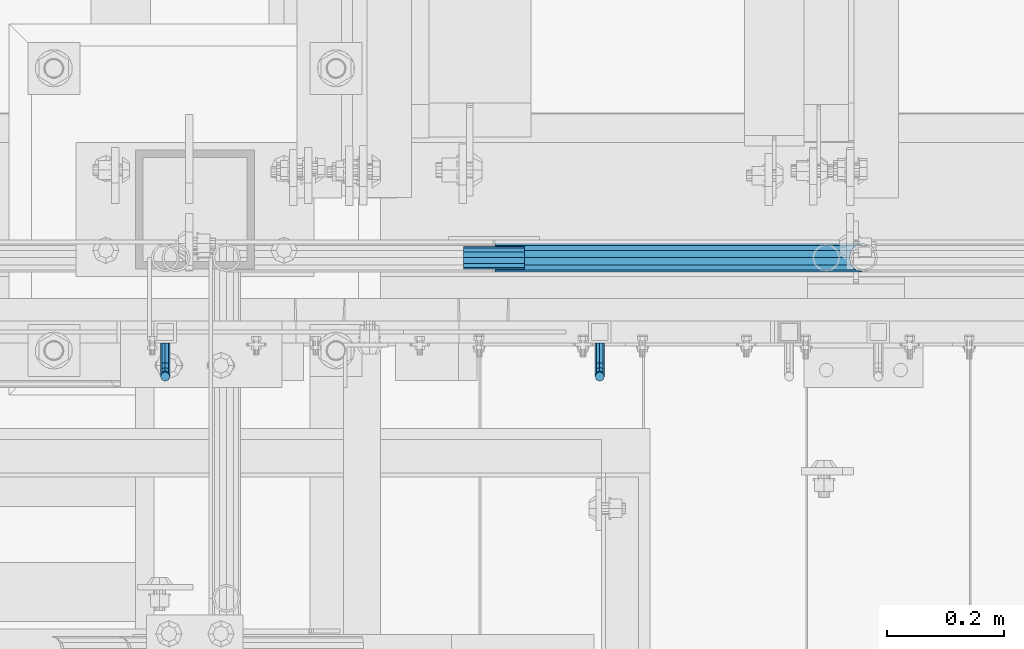
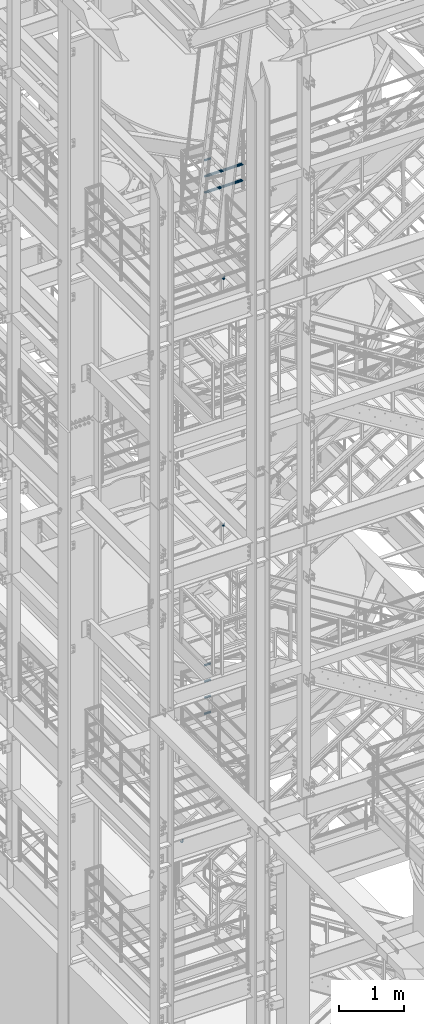
# One storey, part 1172 of 1876: 12 beams, 6 elements without a shape of their own.
"""IFC2X3 building model written with IfcOpenShell, lengths in millimetres."""

from ifc_helpers import new_model, si_unit, frame, origin_with_axes, place, context, subcontext, project, spatial, faceted_brep, material, type_object, element, aggregate, save


model = new_model("IFC2X3")

# Units and contexts
model_context = context("Model", 3, precision=1e-05, world=origin_with_axes())
body_context = subcontext(model_context, "Body", "Model", "MODEL_VIEW")
ifc_project = project(units=[si_unit("LENGTHUNIT", "METRE", prefix="MILLI"), si_unit("AREAUNIT", "SQUARE_METRE"), si_unit("VOLUMEUNIT", "CUBIC_METRE"), si_unit("MASSUNIT", "GRAM", prefix="KILO"), si_unit("TIMEUNIT", "SECOND"), si_unit("PLANEANGLEUNIT", "RADIAN"), si_unit("SOLIDANGLEUNIT", "STERADIAN"), si_unit("THERMODYNAMICTEMPERATUREUNIT", "DEGREE_CELSIUS"), si_unit("LUMINOUSINTENSITYUNIT", "LUMEN")], contexts=[model_context])

# Site, building, storey
site_placement = place(None, origin_with_axes())
site = spatial("IfcSite", under=ifc_project, at=site_placement, CompositionType="ELEMENT")
building_placement = place(site_placement, origin_with_axes())
building = spatial("IfcBuilding", under=site, at=building_placement, Name="Undefined", CompositionType="ELEMENT")
storey_placement = place(building_placement, origin_with_axes())
storey = spatial("IfcBuildingStorey", under=building, at=storey_placement, Name="Undefined", CompositionType="ELEMENT", Elevation=0.0)

# Assembly, beams
assembly_1_placement = place(storey_placement, origin_with_axes())
assembly_1 = element("IfcElementAssembly", 1, at=assembly_1_placement, inside=storey, Name="RAIL", AssemblyPlace="NOTDEFINED", PredefinedType="RIGID_FRAME")
ifc_material_1 = material()
beam_type_1 = type_object("IfcBeamType", Name="PIPE1-1/2SCH40", PredefinedType="NOTDEFINED")
beam_1_placement = place(assembly_1_placement, frame((2870.19999998823, -4654.55000114554, 18145.125), z_axis=(0.0, 0.0, 1.0), x_axis=(-1.0, 0.0, 0.0)))
beam_1 = element("IfcBeam", 2, at=beam_1_placement, type_object=beam_type_1, material=ifc_material_1, Name="RAIL", ObjectType="PIPE1-1/2SCH40", context=body_context, shape_type="Brep", body=[
    faceted_brep([(0.0, 24.1299999999992, 0.0), (12.0650000000064, 20.8971929933177, -12.0649999999987), (12.0650000000064, 20.8971929933177, 12.0649999999987), (12.0650000000064, -20.8971929933177, 12.0649999999987), (12.0650000000064, -20.8971929933177, -12.0649999999987), (0.0, -24.1299999999992, 0.0), (20.8971929933249, -12.0650000000005, 20.8971929933177), (20.8971929933249, -12.0650000000005, 15.8661214311796), (15.2545715621445, -17.7076214311801, 10.2235000000001), (12.5151929933249, -20.4470000000001, 0.0), (15.2545715621445, -17.7076214311801, -10.2235000000001), (20.8971929933249, -12.0650000000005, -15.8661214311796), (20.8971929933249, -12.0650000000005, -20.8971929933177), (24.1300000000063, 0.0, -20.4470000000001), (24.1300000000063, 0.0, -24.130000000001), (21.3906214311868, -10.2235000000001, -17.7076214311819), (21.3906214311868, 10.2235000000001, -17.7076214311819), (20.8971929933249, 12.0650000000005, -15.8661214311796), (20.8971929933249, 12.0650000000005, -20.8971929933177), (15.2545715621445, 17.7076214311801, -10.2235000000001), (12.5151929933249, 20.4470000000001, 0.0), (15.2545715621445, 17.7076214311801, 10.2235000000001), (20.8971929933249, 12.0650000000005, 15.8661214311796), (20.8971929933249, 12.0650000000005, 20.8971929933177), (21.3906214311868, 10.2235000000001, 17.7076214311819), (24.1300000000064, 0.0, 20.4470000000001), (24.1300000000064, 0.0, 24.130000000001), (21.3906214311868, -10.2235000000001, 17.7076214311819), (630.238000000001, -24.1300000000001, 0.0), (630.238000000001, -20.8971929933186, 12.0649999999987), (630.238000000001, -12.0649999999996, 20.8971929933177), (630.238000000001, 0.0, 24.130000000001), (630.238000000001, -12.0649999999996, -20.8971929933177), (630.238000000001, -20.8971929933186, -12.0649999999987), (630.238000000001, 0.0, -24.130000000001), (630.238000000001, 12.0649999999996, -20.8971929933177), (630.238000000001, 20.8971929933186, -12.0649999999987), (630.238000000001, 24.1300000000001, 0.0), (630.238000000001, 20.8971929933186, 12.0649999999987), (630.238000000001, 12.0649999999996, 20.8971929933177), (630.238000000001, -10.2235000000001, 17.7076214311819), (630.238000000001, 0.0, 20.4470000000001), (630.238000000001, 10.2235000000001, 17.7076214311819), (630.238000000001, 17.7076214311801, 10.2235000000001), (630.238000000001, 20.4470000000001, 0.0), (630.238000000001, 17.7076214311801, -10.2235000000001), (630.238000000001, 10.2235000000001, -17.7076214311819), (630.238000000001, 0.0, -20.4470000000001), (630.238000000001, -10.2235000000001, -17.7076214311819), (630.238000000001, -17.7076214311801, -10.2235000000001), (630.238000000001, -20.4470000000001, 0.0), (630.238000000001, -17.7076214311801, 10.2235000000001)], [[[0, 1, 2]], [[3, 4, 5]], [[6, 7, 8, 9, 10, 11, 12, 4, 3]], [[13, 14, 12, 11, 15]], [[16, 17, 18, 14, 13]], [[2, 1, 18, 17, 19, 20, 21, 22, 23]], [[23, 22, 24, 25, 26]], [[26, 25, 27, 7, 6]], [[28, 29, 3, 5]], [[29, 30, 6, 3]], [[30, 31, 26, 6]], [[32, 33, 4, 12]], [[34, 32, 12, 14]], [[35, 34, 14, 18]], [[36, 35, 18, 1]], [[37, 36, 1, 0]], [[38, 37, 0, 2]], [[39, 38, 2, 23]], [[31, 39, 23, 26]], [[33, 28, 5, 4]], [[32, 34, 35, 36, 37, 38, 39, 31, 30, 29, 28, 33], [40, 41, 42, 43, 44, 45, 46, 47, 48, 49, 50, 51]], [[42, 41, 25, 24]], [[21, 43, 42, 24, 22]], [[44, 43, 21, 20]], [[45, 44, 20, 19]], [[46, 45, 19, 17, 16]], [[47, 46, 16, 13]], [[48, 47, 13, 15]], [[10, 49, 48, 15, 11]], [[50, 49, 10, 9]], [[51, 50, 9, 8]], [[40, 51, 8, 7, 27]], [[41, 40, 27, 25]]]),
])
beam_2_placement = place(assembly_1_placement, frame((2238.37499998823, -4654.55000114554, 18449.925), z_axis=(0.0, 0.0, -1.0), x_axis=(1.0, 0.0, 0.0)))
beam_2 = element("IfcBeam", 3, at=beam_2_placement, type_object=beam_type_1, material=ifc_material_1, Name="RAIL", ObjectType="PIPE1-1/2SCH40", context=body_context, shape_type="Brep", body=[
    faceted_brep([(610.92780700668, -12.0649999999996, 20.8971929933177), (610.92780700668, -12.0650000000051, 15.866121431176), (610.434378568817, -10.2235000000001, 17.7076214311819), (607.694999999998, 0.0, 20.4470000000001), (607.694999999998, 0.0, 24.130000000001), (610.434378568819, 10.2235000000001, 17.7076214311819), (610.92780700668, 12.0649999999941, 15.8661214311869), (610.92780700668, 12.0649999999996, 20.8971929933177), (631.825, 24.1300000000001, 0.0), (619.759999999998, 20.8971929933186, 12.0649999999987), (619.759999999998, 20.8971929933186, -12.0649999999987), (616.570428437866, 17.7076214311801, 10.2235000000001), (619.309807006685, 20.4470000000001, 0.0), (616.570428437866, 17.7076214311801, -10.2235000000001), (610.92780700668, 12.0649999999941, -15.8661214311869), (610.92780700668, 12.0649999999996, -20.8971929933177), (610.434378568819, 10.2235000000001, -17.7076214311819), (607.694999999998, 0.0, -20.4470000000001), (607.694999999998, 0.0, -24.130000000001), (610.92780700668, -12.0650000000051, -15.866121431176), (610.92780700668, -12.0649999999996, -20.8971929933177), (610.434378568817, -10.2235000000001, -17.7076214311819), (631.824999999998, -24.1300000000056, 0.0), (619.759999999998, -20.8971929933186, -12.0649999999987), (619.759999999998, -20.8971929933186, 12.0649999999987), (616.570428437855, -17.7076214311801, -10.2235000000001), (619.309807006674, -20.4470000000001, 0.0), (616.570428437855, -17.7076214311801, 10.2235000000001), (1.58700000000044, -20.8971929933186, -12.0649999999996), (1.58700000000044, -12.0649999999996, -20.8971929933186), (1.58700000000044, 0.0, -24.1300000000001), (1.58700000000044, 12.0649999999996, -20.8971929933186), (1.58700000000044, 20.8971929933186, -12.0649999999996), (1.58700000000044, 24.1300000000001, 0.0), (1.58700000000044, 20.8971929933186, 12.0649999999996), (1.58700000000044, 12.0649999999996, 20.8971929933186), (1.58700000000044, 0.0, 24.1300000000001), (1.58700000000044, -12.0649999999996, 20.8971929933186), (1.58700000000044, -20.8971929933186, 12.0649999999996), (1.58700000000044, -24.1300000000001, 0.0), (1.58700000000044, -17.7076214311801, -10.2235000000001), (1.58700000000044, -10.2235000000001, -17.7076214311801), (1.58700000000044, 0.0, -20.4470000000001), (1.58700000000044, 10.2235000000001, -17.7076214311801), (1.58700000000044, 17.7076214311801, -10.2235000000001), (1.58700000000044, 20.4470000000001, 0.0), (1.58700000000044, 17.7076214311801, 10.2235000000001), (1.58700000000044, 10.2235000000001, 17.7076214311801), (1.58700000000044, 0.0, 20.4470000000001), (1.58700000000044, -10.2235000000001, 17.7076214311801), (1.58700000000044, -17.7076214311801, 10.2235000000001), (1.58700000000044, -20.4470000000001, 0.0)], [[[0, 1, 2, 3, 4]], [[4, 3, 5, 6, 7]], [[8, 9, 10]], [[7, 6, 11, 12, 13, 14, 15, 10, 9]], [[16, 17, 18, 15, 14]], [[19, 20, 18, 17, 21]], [[22, 23, 24]], [[24, 23, 20, 19, 25, 26, 27, 1, 0]], [[28, 29, 20, 23]], [[29, 30, 18, 20]], [[30, 31, 15, 18]], [[31, 32, 10, 15]], [[32, 33, 8, 10]], [[33, 34, 9, 8]], [[34, 35, 7, 9]], [[35, 36, 4, 7]], [[36, 37, 0, 4]], [[37, 38, 24, 0]], [[38, 39, 22, 24]], [[39, 28, 23, 22]], [[38, 37, 36, 35, 34, 33, 32, 31, 30, 29, 28, 39], [40, 41, 42, 43, 44, 45, 46, 47, 48, 49, 50, 51]], [[40, 51, 26, 25]], [[21, 41, 40, 25, 19]], [[42, 41, 21, 17]], [[43, 42, 17, 16]], [[44, 43, 16, 14, 13]], [[45, 44, 13, 12]], [[46, 45, 12, 11]], [[5, 47, 46, 11, 6]], [[48, 47, 5, 3]], [[49, 48, 3, 2]], [[50, 49, 2, 1, 27]], [[51, 50, 27, 26]]]),
])
aggregate(assembly_1, [beam_1, beam_2])

# Assembly, beam
assembly_2_placement = place(storey_placement, origin_with_axes())
assembly_2 = element("IfcElementAssembly", 4, at=assembly_2_placement, inside=storey, Name="RAIL", AssemblyPlace="NOTDEFINED", PredefinedType="RIGID_FRAME")
ifc_material_2 = material(Name="STEEL/A36")
beam_type_2 = type_object("IfcBeamType", PredefinedType="NOTDEFINED")
beam_3_placement = place(assembly_2_placement, frame((2419.35000034996, -4800.59999885446, 11882.9282225472), z_axis=(1.0, 0.0, 0.0), x_axis=(0.0, -1.0, 0.0)))
beam_3 = element("IfcBeam", 5, at=beam_3_placement, type_object=beam_type_2, material=ifc_material_2, Name="BRACKET", context=body_context, shape_type="Brep", body=[
    faceted_brep([(0.0, -5.61266007566822, 5.61266007566883), (0.0, 0.0, 7.9375), (0.0, 5.61266007566822, 5.61266007566883), (0.0, 7.9375, 0.0), (0.0, 5.61266007566822, -5.61266007566883), (0.0, 0.0, -7.9375), (0.0, -5.61266007566822, -5.61266007566883), (0.0, -7.9375, 0.0), (23.8125, 5.61266007566883, 5.61266007566792), (23.8125, 7.9375, 0.0), (23.8125, 5.61266007566883, -5.61266007566792), (23.8125, 0.0, -7.9375), (23.8125, -5.61266007566883, -5.61266007566792), (23.8125, -7.9375, 0.0), (23.8125, -5.61266007566883, 5.61266007566792), (23.8125, 0.0, 7.9375), (36.5702095103989, -2.53766620105534, 7.9375), (38.7180815328547, 2.64775556579752, 5.61266007566792), (39.6077592547972, 4.79562758825296, 0.0), (38.7180815328547, 2.64775556579752, -5.61266007566792), (36.5702095103989, -2.53766620105534, -7.9375), (34.4223374879439, -7.72308796790867, -5.61266007566792), (33.5326597660014, -9.87095999036364, 0.0), (34.4223374879439, -7.72308796790867, 5.61266007566792), (43.4169233967659, -13.733078129113, 5.61266007566792), (47.385673396765, -9.76432812911298, 7.9375), (41.7730133210971, -15.3769882047809, 0.0), (43.4169233967659, -13.733078129113, -5.61266007566792), (47.385673396765, -9.76432812911298, -7.9375), (51.354423396765, -5.79557812911253, -5.61266007566792), (52.9983334724338, -4.15166805344461, 0.0), (51.354423396765, -5.79557812911253, 5.61266007566792), (54.6123353248231, -20.5797920154787, 7.9375), (59.7977570916764, -18.4319199930233, 5.61266007566792), (49.4269135579698, -22.7276640379341, 5.61266007566792), (47.2790415355148, -23.6173417598766, 0.0), (49.4269135579698, -22.7276640379341, -5.61266007566792), (54.6123353248231, -20.5797920154787, -7.9375), (59.7977570916764, -18.4319199930233, -5.61266007566792), (61.9456291141314, -17.5422422710808, 0.0), (62.7626616015468, -33.3375015258789, 5.61266007566792), (65.0875015258789, -33.3375015258789, 0.0), (57.1500015258789, -33.3375015258789, 7.9375), (51.5373414502101, -33.3375015258789, 5.61266007566792), (49.2125015258789, -33.3375015258789, 0.0), (51.5373414502101, -33.3375015258789, -5.61266007566792), (57.1500015258789, -33.3375015258789, -7.9375), (62.7626616015468, -33.3375015258789, -5.61266007566792), (65.0875015258789, -66.5341532333514, 2.45290721068159e-09), (62.7626616015805, -63.0815171359536, -5.61266007334871), (57.1500015259289, -61.6513884384531, -7.93749999776537), (51.5373414502437, -63.0815171359118, -5.6126600734151), (49.2125015258789, -66.5341532333259, 2.41197994910181e-09), (51.5373414501864, -69.9867893307037, 5.61266007818085), (57.1500015258471, -71.4169180281988, 7.93750000258842), (62.7626616015223, -69.9867893307346, 5.61266007822906)], [[[0, 1, 2, 3, 4, 5, 6, 7]], [[3, 2, 8, 9]], [[4, 3, 9, 10]], [[5, 4, 10, 11]], [[6, 5, 11, 12]], [[7, 6, 12, 13]], [[0, 7, 13, 14]], [[1, 0, 14, 15]], [[2, 1, 15, 8]], [[8, 15, 16, 17]], [[9, 8, 17, 18]], [[10, 9, 18, 19]], [[11, 10, 19, 20]], [[12, 11, 20, 21]], [[13, 12, 21, 22]], [[14, 13, 22, 23]], [[15, 14, 23, 16]], [[23, 24, 25, 16]], [[22, 26, 24, 23]], [[21, 27, 26, 22]], [[20, 28, 27, 21]], [[19, 29, 28, 20]], [[18, 30, 29, 19]], [[17, 31, 30, 18]], [[16, 25, 31, 17]], [[25, 32, 33, 31]], [[24, 34, 32, 25]], [[26, 35, 34, 24]], [[27, 36, 35, 26]], [[28, 37, 36, 27]], [[29, 38, 37, 28]], [[30, 39, 38, 29]], [[31, 33, 39, 30]], [[33, 40, 41, 39]], [[32, 42, 40, 33]], [[34, 43, 42, 32]], [[35, 44, 43, 34]], [[36, 45, 44, 35]], [[37, 46, 45, 36]], [[38, 47, 46, 37]], [[39, 41, 47, 38]], [[47, 41, 48, 49]], [[46, 47, 49, 50]], [[45, 46, 50, 51]], [[44, 45, 51, 52]], [[43, 44, 52, 53]], [[42, 43, 53, 54]], [[40, 42, 54, 55]], [[41, 40, 55, 48]], [[54, 53, 52, 51, 50, 49, 48, 55]]]),
])
aggregate(assembly_2, [beam_3])

assembly_3_placement = place(storey_placement, origin_with_axes())
assembly_3 = element("IfcElementAssembly", 6, at=assembly_3_placement, inside=storey, Name="RAIL", AssemblyPlace="NOTDEFINED", PredefinedType="RIGID_FRAME")
beam_4_placement = place(assembly_3_placement, frame((1676.40000030575, -4800.59999885446, 6175.95228073486), z_axis=(1.0, 0.0, 0.0), x_axis=(0.0, -1.0, 0.0)))
beam_4 = element("IfcBeam", 7, at=beam_4_placement, type_object=beam_type_2, material=ifc_material_2, Name="BRACKET", context=body_context, shape_type="Brep", body=[
    faceted_brep([(0.0, -5.61266007566822, 5.61266007566883), (0.0, 0.0, 7.9375), (0.0, 5.61266007566822, 5.61266007566883), (0.0, 7.9375, 0.0), (0.0, 5.61266007566822, -5.61266007566883), (0.0, 0.0, -7.9375), (0.0, -5.61266007566822, -5.61266007566883), (0.0, -7.9375, 0.0), (23.8125, 5.61266007566883, 5.61266007566792), (23.8125, 7.9375, 0.0), (23.8125, 5.61266007566883, -5.61266007566792), (23.8125, 0.0, -7.9375), (23.8125, -5.61266007566883, -5.61266007566792), (23.8125, -7.9375, 0.0), (23.8125, -5.61266007566883, 5.61266007566792), (23.8125, 0.0, 7.9375), (36.5702095103989, -2.53766620105534, 7.9375), (38.7180815328547, 2.64775556579752, 5.61266007566792), (39.6077592547972, 4.79562758825296, 0.0), (38.7180815328547, 2.64775556579752, -5.61266007566792), (36.5702095103989, -2.53766620105534, -7.9375), (34.4223374879439, -7.72308796790867, -5.61266007566792), (33.5326597660014, -9.87095999036364, 0.0), (34.4223374879439, -7.72308796790867, 5.61266007566792), (43.4169233967659, -13.733078129113, 5.61266007566792), (47.385673396765, -9.76432812911298, 7.9375), (41.7730133210971, -15.3769882047809, 0.0), (43.4169233967659, -13.733078129113, -5.61266007566792), (47.385673396765, -9.76432812911298, -7.9375), (51.354423396765, -5.79557812911253, -5.61266007566792), (52.9983334724338, -4.15166805344461, 0.0), (51.354423396765, -5.79557812911253, 5.61266007566792), (54.6123353248231, -20.5797920154787, 7.9375), (59.7977570916764, -18.4319199930233, 5.61266007566792), (49.4269135579698, -22.7276640379341, 5.61266007566792), (47.2790415355148, -23.6173417598766, 0.0), (49.4269135579698, -22.7276640379341, -5.61266007566792), (54.6123353248231, -20.5797920154787, -7.9375), (59.7977570916764, -18.4319199930233, -5.61266007566792), (61.9456291141314, -17.5422422710808, 0.0), (62.7626616015468, -33.3375015258789, 5.61266007566792), (65.0875015258789, -33.3375015258789, 0.0), (57.1500015258789, -33.3375015258789, 7.9375), (51.5373414502101, -33.3375015258789, 5.61266007566792), (49.2125015258789, -33.3375015258789, 0.0), (51.5373414502101, -33.3375015258789, -5.61266007566792), (57.1500015258789, -33.3375015258789, -7.9375), (62.7626616015468, -33.3375015258789, -5.61266007566792), (65.0875015258789, -66.3198535804604, 0.0), (62.7626616015468, -62.7481608643047, -5.61266007566792), (57.1500015258789, -61.2687173006434, -7.9375), (51.537341450211, -62.7481608643047, -5.61266007566792), (49.2125015258789, -66.3198535804604, 0.0), (51.537341450211, -69.8915462966161, 5.61266007566792), (57.1500015258789, -71.3709898602756, 7.9375), (62.7626616015468, -69.8915462966161, 5.61266007566792)], [[[0, 1, 2, 3, 4, 5, 6, 7]], [[3, 2, 8, 9]], [[4, 3, 9, 10]], [[5, 4, 10, 11]], [[6, 5, 11, 12]], [[7, 6, 12, 13]], [[0, 7, 13, 14]], [[1, 0, 14, 15]], [[2, 1, 15, 8]], [[8, 15, 16, 17]], [[9, 8, 17, 18]], [[10, 9, 18, 19]], [[11, 10, 19, 20]], [[12, 11, 20, 21]], [[13, 12, 21, 22]], [[14, 13, 22, 23]], [[15, 14, 23, 16]], [[23, 24, 25, 16]], [[22, 26, 24, 23]], [[21, 27, 26, 22]], [[20, 28, 27, 21]], [[19, 29, 28, 20]], [[18, 30, 29, 19]], [[17, 31, 30, 18]], [[16, 25, 31, 17]], [[25, 32, 33, 31]], [[24, 34, 32, 25]], [[26, 35, 34, 24]], [[27, 36, 35, 26]], [[28, 37, 36, 27]], [[29, 38, 37, 28]], [[30, 39, 38, 29]], [[31, 33, 39, 30]], [[33, 40, 41, 39]], [[32, 42, 40, 33]], [[34, 43, 42, 32]], [[35, 44, 43, 34]], [[36, 45, 44, 35]], [[37, 46, 45, 36]], [[38, 47, 46, 37]], [[39, 41, 47, 38]], [[47, 41, 48, 49]], [[46, 47, 49, 50]], [[45, 46, 50, 51]], [[44, 45, 51, 52]], [[43, 44, 52, 53]], [[42, 43, 53, 54]], [[40, 42, 54, 55]], [[41, 40, 55, 48]], [[54, 53, 52, 51, 50, 49, 48, 55]]]),
])
aggregate(assembly_3, [beam_4])

assembly_4_placement = place(storey_placement, origin_with_axes())
assembly_4 = element("IfcElementAssembly", 8, at=assembly_4_placement, inside=storey, Name="RAIL", AssemblyPlace="NOTDEFINED", PredefinedType="RIGID_FRAME")
beam_5_placement = place(assembly_4_placement, frame((2419.34999989024, -4800.60000114554, 16540.4354524847), z_axis=(-1.0, 0.0, 0.0), x_axis=(0.0, -1.0, 0.0)))
beam_5 = element("IfcBeam", 9, at=beam_5_placement, type_object=beam_type_2, material=ifc_material_2, Name="BRACKET", context=body_context, shape_type="Brep", body=[
    faceted_brep([(0.0, -5.61266007566822, 5.61266007566883), (0.0, 0.0, 7.9375), (0.0, 5.61266007566822, 5.61266007566883), (0.0, 7.9375, 0.0), (0.0, 5.61266007566822, -5.61266007566883), (0.0, 0.0, -7.9375), (0.0, -5.61266007566822, -5.61266007566883), (0.0, -7.9375, 0.0), (23.8125, -5.61266007566883, -5.61266007566792), (23.8125, -7.9375, 0.0), (23.8125, -5.61266007566883, 5.61266007566792), (23.8125, 0.0, 7.9375), (23.8125, 5.61266007566883, 5.61266007566792), (23.8125, 7.9375, 0.0), (23.8125, 5.61266007566883, -5.61266007566792), (23.8125, 0.0, -7.9375), (36.5702095103998, 2.53766620105671, -7.9375), (38.7180815328556, -2.64775556579843, -5.61266007566792), (39.6077592547981, -4.79562758825341, 0.0), (38.7180815328556, -2.64775556579843, 5.61266007566792), (36.5702095103998, 2.53766620105671, 7.9375), (34.4223374879448, 7.72308796790821, 5.61266007566792), (33.5326597660023, 9.87095999036319, 0.0), (34.4223374879448, 7.72308796790821, -5.61266007566792), (43.4169233967659, 13.733078129113, -5.61266007566792), (47.3856733967659, 9.76432812911298, -7.9375), (41.773013321098, 15.3769882047818, 0.0), (43.4169233967659, 13.733078129113, 5.61266007566792), (47.3856733967659, 9.76432812911298, 7.9375), (51.3544233967659, 5.79557812911298, 5.61266007566792), (52.9983334724348, 4.15166805344415, 0.0), (51.3544233967659, 5.79557812911298, -5.61266007566792), (54.6123353248231, 20.5797920154801, -7.9375), (59.7977570916764, 18.4319199930251, -5.61266007566792), (49.4269135579698, 22.727664037935, -5.61266007566792), (47.2790415355148, 23.6173417598766, 0.0), (49.4269135579698, 22.727664037935, 5.61266007566792), (54.6123353248231, 20.5797920154801, 7.9375), (59.7977570916764, 18.4319199930251, 5.61266007566792), (61.9456291141314, 17.5422422710835, 0.0), (62.7626616015468, 33.3375015258789, -5.61266007566792), (65.0875015258789, 33.3375015258789, 0.0), (57.1500015258789, 33.3375015258789, -7.9375), (51.5373414502101, 33.3375015258789, -5.61266007566792), (49.2125015258789, 33.3375015258789, 0.0), (51.5373414502101, 33.3375015258789, 5.61266007566792), (57.1500015258789, 33.3375015258789, 7.9375), (62.7626616015468, 33.3375015258789, 5.61266007566792), (65.0875015258789, 66.4903820289292, 0.0), (62.7626616015468, 63.0131702244908, 5.61266007566837), (57.1500015258789, 61.5728619358488, 7.9375), (51.537341450211, 63.0131702244908, 5.61266007566837), (49.2125015258789, 66.4903820289292, 0.0), (51.537341450211, 69.9675938333676, -5.61266007566837), (57.1500015258789, 71.4079021220132, -7.9375), (62.7626616015468, 69.9675938333676, -5.61266007566837)], [[[0, 1, 2, 3, 4, 5, 6, 7]], [[7, 6, 8, 9]], [[0, 7, 9, 10]], [[1, 0, 10, 11]], [[2, 1, 11, 12]], [[3, 2, 12, 13]], [[4, 3, 13, 14]], [[5, 4, 14, 15]], [[6, 5, 15, 8]], [[8, 15, 16, 17]], [[9, 8, 17, 18]], [[10, 9, 18, 19]], [[11, 10, 19, 20]], [[12, 11, 20, 21]], [[13, 12, 21, 22]], [[14, 13, 22, 23]], [[15, 14, 23, 16]], [[23, 24, 25, 16]], [[22, 26, 24, 23]], [[21, 27, 26, 22]], [[20, 28, 27, 21]], [[19, 29, 28, 20]], [[18, 30, 29, 19]], [[17, 31, 30, 18]], [[16, 25, 31, 17]], [[25, 32, 33, 31]], [[24, 34, 32, 25]], [[26, 35, 34, 24]], [[27, 36, 35, 26]], [[28, 37, 36, 27]], [[29, 38, 37, 28]], [[30, 39, 38, 29]], [[31, 33, 39, 30]], [[33, 40, 41, 39]], [[32, 42, 40, 33]], [[34, 43, 42, 32]], [[35, 44, 43, 34]], [[36, 45, 44, 35]], [[37, 46, 45, 36]], [[38, 47, 46, 37]], [[39, 41, 47, 38]], [[47, 41, 48, 49]], [[46, 47, 49, 50]], [[45, 46, 50, 51]], [[44, 45, 51, 52]], [[43, 44, 52, 53]], [[42, 43, 53, 54]], [[40, 42, 54, 55]], [[41, 40, 55, 48]], [[54, 53, 52, 51, 50, 49, 48, 55]]]),
])
aggregate(assembly_4, [beam_5])

# Assembly, beams
assembly_5_placement = place(storey_placement, origin_with_axes())
assembly_5 = element("IfcElementAssembly", 10, at=assembly_5_placement, inside=storey, Name="RAIL", AssemblyPlace="NOTDEFINED", PredefinedType="RIGID_FRAME")
beam_type_3 = type_object("IfcBeamType", PredefinedType="NOTDEFINED")
beam_6_placement = place(assembly_5_placement, frame((2185.98799998823, -4654.54995231742, 18145.125), z_axis=(0.0, 0.0, 1.0), x_axis=(1.0, 0.0, 0.0)))
beam_6 = element("IfcBeam", 11, at=beam_6_placement, type_object=beam_type_3, material=ifc_material_2, Name="ROD", context=body_context, shape_type="Brep", body=[
    faceted_brep([(0.0, -18.8594999999996, 0.0), (0.0, -16.3328061026723, -9.42975000000024), (104.774, -16.3328061026723, -9.42975000000024), (104.774, -18.8594999999996, 0.0), (0.0, -9.42975000000024, -16.3328061026723), (104.774, -9.42975000000024, -16.3328061026723), (0.0, 0.0, -18.8594999999996), (104.774, 0.0, -18.8594999999996), (0.0, 9.42975000000024, -16.3328061026723), (104.774, 9.42975000000024, -16.3328061026723), (0.0, 16.3328061026723, -9.42975000000024), (104.774, 16.3328061026723, -9.42975000000024), (0.0, 18.8594999999996, 0.0), (104.774, 18.8594999999996, 0.0), (0.0, 16.3328061026723, 9.42975000000024), (104.774, 16.3328061026723, 9.42975000000024), (0.0, 9.42975000000024, 16.3328061026723), (104.774, 9.42975000000024, 16.3328061026723), (0.0, 0.0, 18.8594999999996), (104.774, 0.0, 18.8594999999996), (0.0, -9.42975000000024, 16.3328061026723), (104.774, -9.42975000000024, 16.3328061026723), (0.0, -16.3328061026723, 9.42975000000024), (104.774, -16.3328061026723, 9.42975000000024)], [[[0, 1, 2, 3]], [[1, 4, 5, 2]], [[4, 6, 7, 5]], [[6, 8, 9, 7]], [[8, 10, 11, 9]], [[10, 12, 13, 11]], [[12, 14, 15, 13]], [[14, 16, 17, 15]], [[16, 18, 19, 17]], [[18, 20, 21, 19]], [[20, 22, 23, 21]], [[22, 0, 3, 23]], [[5, 7, 9, 11, 13, 15, 17, 19, 21, 23, 3, 2]], [[22, 20, 18, 16, 14, 12, 10, 8, 6, 4, 1, 0]]]),
])
beam_7_placement = place(assembly_5_placement, frame((2185.98799998823, -4654.54995231742, 18449.925), z_axis=(0.0, 0.0, 1.0), x_axis=(1.0, 0.0, 0.0)))
beam_7 = element("IfcBeam", 12, at=beam_7_placement, type_object=beam_type_3, material=ifc_material_2, Name="ROD", context=body_context, shape_type="Brep", body=[
    faceted_brep([(0.0, -18.8594999999996, 0.0), (0.0, -16.3328061026723, -9.42975000000024), (104.774, -16.3328061026723, -9.42975000000024), (104.774, -18.8594999999996, 0.0), (0.0, -9.42975000000024, -16.3328061026723), (104.774, -9.42975000000024, -16.3328061026723), (0.0, 0.0, -18.8594999999996), (104.774, 0.0, -18.8594999999996), (0.0, 9.42975000000024, -16.3328061026723), (104.774, 9.42975000000024, -16.3328061026723), (0.0, 16.3328061026723, -9.42975000000024), (104.774, 16.3328061026723, -9.42975000000024), (0.0, 18.8594999999996, 0.0), (104.774, 18.8594999999996, 0.0), (0.0, 16.3328061026723, 9.42975000000024), (104.774, 16.3328061026723, 9.42975000000024), (0.0, 9.42975000000024, 16.3328061026723), (104.774, 9.42975000000024, 16.3328061026723), (0.0, 0.0, 18.8594999999996), (104.774, 0.0, 18.8594999999996), (0.0, -9.42975000000024, 16.3328061026723), (104.774, -9.42975000000024, 16.3328061026723), (0.0, -16.3328061026723, 9.42975000000024), (104.774, -16.3328061026723, 9.42975000000024)], [[[0, 1, 2, 3]], [[1, 4, 5, 2]], [[4, 6, 7, 5]], [[6, 8, 9, 7]], [[8, 10, 11, 9]], [[10, 12, 13, 11]], [[12, 14, 15, 13]], [[14, 16, 17, 15]], [[16, 18, 19, 17]], [[18, 20, 21, 19]], [[20, 22, 23, 21]], [[22, 0, 3, 23]], [[5, 7, 9, 11, 13, 15, 17, 19, 21, 23, 3, 2]], [[22, 20, 18, 16, 14, 12, 10, 8, 6, 4, 1, 0]]]),
])
beam_8_placement = place(assembly_5_placement, frame((2185.98799998823, -4654.54995231742, 18754.725), z_axis=(0.0, 0.0, 1.0), x_axis=(1.0, 0.0, 0.0)))
beam_8 = element("IfcBeam", 13, at=beam_8_placement, type_object=beam_type_3, material=ifc_material_2, Name="ROD", context=body_context, shape_type="Brep", body=[
    faceted_brep([(0.0, -18.8594999999996, 0.0), (0.0, -16.3328061026723, -9.42975000000024), (104.774, -16.3328061026723, -9.42975000000024), (104.774, -18.8594999999996, 0.0), (0.0, -9.42975000000024, -16.3328061026723), (104.774, -9.42975000000024, -16.3328061026723), (0.0, 0.0, -18.8594999999996), (104.774, 0.0, -18.8594999999996), (0.0, 9.42975000000024, -16.3328061026723), (104.774, 9.42975000000024, -16.3328061026723), (0.0, 16.3328061026723, -9.42975000000024), (104.774, 16.3328061026723, -9.42975000000024), (0.0, 18.8594999999996, 0.0), (104.774, 18.8594999999996, 0.0), (0.0, 16.3328061026723, 9.42975000000024), (104.774, 16.3328061026723, 9.42975000000024), (0.0, 9.42975000000024, 16.3328061026723), (104.774, 9.42975000000024, 16.3328061026723), (0.0, 0.0, 18.8594999999996), (104.774, 0.0, 18.8594999999996), (0.0, -9.42975000000024, 16.3328061026723), (104.774, -9.42975000000024, 16.3328061026723), (0.0, -16.3328061026723, 9.42975000000024), (104.774, -16.3328061026723, 9.42975000000024)], [[[0, 1, 2, 3]], [[1, 4, 5, 2]], [[4, 6, 7, 5]], [[6, 8, 9, 7]], [[8, 10, 11, 9]], [[10, 12, 13, 11]], [[12, 14, 15, 13]], [[14, 16, 17, 15]], [[16, 18, 19, 17]], [[18, 20, 21, 19]], [[20, 22, 23, 21]], [[22, 0, 3, 23]], [[5, 7, 9, 11, 13, 15, 17, 19, 21, 23, 3, 2]], [[22, 20, 18, 16, 14, 12, 10, 8, 6, 4, 1, 0]]]),
])
aggregate(assembly_5, [beam_6, beam_7, beam_8])

assembly_6_placement = place(storey_placement, origin_with_axes())
assembly_6 = element("IfcElementAssembly", 14, at=assembly_6_placement, inside=storey, Name="RAIL", AssemblyPlace="NOTDEFINED", PredefinedType="RIGID_FRAME")
beam_9_placement = place(assembly_6_placement, frame((2185.98799998823, -4654.54995231742, 8315.325), z_axis=(0.0, 0.0, 1.0), x_axis=(1.0, 0.0, 0.0)))
beam_9 = element("IfcBeam", 15, at=beam_9_placement, type_object=beam_type_3, material=ifc_material_2, Name="ROD", context=body_context, shape_type="Brep", body=[
    faceted_brep([(0.0, -18.8594999999996, 0.0), (0.0, -16.3328061026723, -9.42975000000024), (104.774, -16.3328061026723, -9.42975000000024), (104.774, -18.8594999999996, 0.0), (0.0, -9.42975000000024, -16.3328061026723), (104.774, -9.42975000000024, -16.3328061026723), (0.0, 0.0, -18.8594999999996), (104.774, 0.0, -18.8594999999996), (0.0, 9.42975000000024, -16.3328061026723), (104.774, 9.42975000000024, -16.3328061026723), (0.0, 16.3328061026723, -9.42975000000024), (104.774, 16.3328061026723, -9.42975000000024), (0.0, 18.8594999999996, 0.0), (104.774, 18.8594999999996, 0.0), (0.0, 16.3328061026723, 9.42975000000024), (104.774, 16.3328061026723, 9.42975000000024), (0.0, 9.42975000000024, 16.3328061026723), (104.774, 9.42975000000024, 16.3328061026723), (0.0, 0.0, 18.8594999999996), (104.774, 0.0, 18.8594999999996), (0.0, -9.42975000000024, 16.3328061026723), (104.774, -9.42975000000024, 16.3328061026723), (0.0, -16.3328061026723, 9.42975000000024), (104.774, -16.3328061026723, 9.42975000000024)], [[[0, 1, 2, 3]], [[1, 4, 5, 2]], [[4, 6, 7, 5]], [[6, 8, 9, 7]], [[8, 10, 11, 9]], [[10, 12, 13, 11]], [[12, 14, 15, 13]], [[14, 16, 17, 15]], [[16, 18, 19, 17]], [[18, 20, 21, 19]], [[20, 22, 23, 21]], [[22, 0, 3, 23]], [[5, 7, 9, 11, 13, 15, 17, 19, 21, 23, 3, 2]], [[22, 20, 18, 16, 14, 12, 10, 8, 6, 4, 1, 0]]]),
])
beam_10_placement = place(assembly_6_placement, frame((2185.98799998823, -4654.54995231742, 8620.125), z_axis=(0.0, 0.0, 1.0), x_axis=(1.0, 0.0, 0.0)))
beam_10 = element("IfcBeam", 16, at=beam_10_placement, type_object=beam_type_3, material=ifc_material_2, Name="ROD", context=body_context, shape_type="Brep", body=[
    faceted_brep([(0.0, -18.8594999999996, 0.0), (0.0, -16.3328061026723, -9.42975000000024), (104.774, -16.3328061026723, -9.42975000000024), (104.774, -18.8594999999996, 0.0), (0.0, -9.42975000000024, -16.3328061026723), (104.774, -9.42975000000024, -16.3328061026723), (0.0, 0.0, -18.8594999999996), (104.774, 0.0, -18.8594999999996), (0.0, 9.42975000000024, -16.3328061026723), (104.774, 9.42975000000024, -16.3328061026723), (0.0, 16.3328061026723, -9.42975000000024), (104.774, 16.3328061026723, -9.42975000000024), (0.0, 18.8594999999996, 0.0), (104.774, 18.8594999999996, 0.0), (0.0, 16.3328061026723, 9.42975000000024), (104.774, 16.3328061026723, 9.42975000000024), (0.0, 9.42975000000024, 16.3328061026723), (104.774, 9.42975000000024, 16.3328061026723), (0.0, 0.0, 18.8594999999996), (104.774, 0.0, 18.8594999999996), (0.0, -9.42975000000024, 16.3328061026723), (104.774, -9.42975000000024, 16.3328061026723), (0.0, -16.3328061026723, 9.42975000000024), (104.774, -16.3328061026723, 9.42975000000024)], [[[0, 1, 2, 3]], [[1, 4, 5, 2]], [[4, 6, 7, 5]], [[6, 8, 9, 7]], [[8, 10, 11, 9]], [[10, 12, 13, 11]], [[12, 14, 15, 13]], [[14, 16, 17, 15]], [[16, 18, 19, 17]], [[18, 20, 21, 19]], [[20, 22, 23, 21]], [[22, 0, 3, 23]], [[5, 7, 9, 11, 13, 15, 17, 19, 21, 23, 3, 2]], [[22, 20, 18, 16, 14, 12, 10, 8, 6, 4, 1, 0]]]),
])
beam_11_placement = place(assembly_6_placement, frame((2185.98799998823, -4654.54995231742, 8924.925), z_axis=(0.0, 0.0, 1.0), x_axis=(1.0, 0.0, 0.0)))
beam_11 = element("IfcBeam", 17, at=beam_11_placement, type_object=beam_type_3, material=ifc_material_2, Name="ROD", context=body_context, shape_type="Brep", body=[
    faceted_brep([(0.0, -18.8594999999996, 0.0), (0.0, -16.3328061026723, -9.42975000000024), (104.774, -16.3328061026723, -9.42975000000024), (104.774, -18.8594999999996, 0.0), (0.0, -9.42975000000024, -16.3328061026723), (104.774, -9.42975000000024, -16.3328061026723), (0.0, 0.0, -18.8594999999996), (104.774, 0.0, -18.8594999999996), (0.0, 9.42975000000024, -16.3328061026723), (104.774, 9.42975000000024, -16.3328061026723), (0.0, 16.3328061026723, -9.42975000000024), (104.774, 16.3328061026723, -9.42975000000024), (0.0, 18.8594999999996, 0.0), (104.774, 18.8594999999996, 0.0), (0.0, 16.3328061026723, 9.42975000000024), (104.774, 16.3328061026723, 9.42975000000024), (0.0, 9.42975000000024, 16.3328061026723), (104.774, 9.42975000000024, 16.3328061026723), (0.0, 0.0, 18.8594999999996), (104.774, 0.0, 18.8594999999996), (0.0, -9.42975000000024, 16.3328061026723), (104.774, -9.42975000000024, 16.3328061026723), (0.0, -16.3328061026723, 9.42975000000024), (104.774, -16.3328061026723, 9.42975000000024)], [[[0, 1, 2, 3]], [[1, 4, 5, 2]], [[4, 6, 7, 5]], [[6, 8, 9, 7]], [[8, 10, 11, 9]], [[10, 12, 13, 11]], [[12, 14, 15, 13]], [[14, 16, 17, 15]], [[16, 18, 19, 17]], [[18, 20, 21, 19]], [[20, 22, 23, 21]], [[22, 0, 3, 23]], [[5, 7, 9, 11, 13, 15, 17, 19, 21, 23, 3, 2]], [[22, 20, 18, 16, 14, 12, 10, 8, 6, 4, 1, 0]]]),
])
beam_12_placement = place(assembly_6_placement, frame((2185.98799998822, -4654.54995231742, 9229.725), z_axis=(0.0, 0.0, 1.0), x_axis=(1.0, 0.0, 0.0)))
beam_12 = element("IfcBeam", 18, at=beam_12_placement, type_object=beam_type_3, material=ifc_material_2, Name="ROD", context=body_context, shape_type="Brep", body=[
    faceted_brep([(0.0, -18.8594999999996, 0.0), (0.0, -16.3328061026723, -9.42975000000024), (104.774, -16.3328061026723, -9.42975000000024), (104.774, -18.8594999999996, 0.0), (0.0, -9.42975000000024, -16.3328061026723), (104.774, -9.42975000000024, -16.3328061026723), (0.0, 0.0, -18.8594999999996), (104.774, 0.0, -18.8594999999996), (0.0, 9.42975000000024, -16.3328061026723), (104.774, 9.42975000000024, -16.3328061026723), (0.0, 16.3328061026723, -9.42975000000024), (104.774, 16.3328061026723, -9.42975000000024), (0.0, 18.8594999999996, 0.0), (104.774, 18.8594999999996, 0.0), (0.0, 16.3328061026723, 9.42975000000024), (104.774, 16.3328061026723, 9.42975000000024), (0.0, 9.42975000000024, 16.3328061026723), (104.774, 9.42975000000024, 16.3328061026723), (0.0, 0.0, 18.8594999999996), (104.774, 0.0, 18.8594999999996), (0.0, -9.42975000000024, 16.3328061026723), (104.774, -9.42975000000024, 16.3328061026723), (0.0, -16.3328061026723, 9.42975000000024), (104.774, -16.3328061026723, 9.42975000000024)], [[[0, 1, 2, 3]], [[1, 4, 5, 2]], [[4, 6, 7, 5]], [[6, 8, 9, 7]], [[8, 10, 11, 9]], [[10, 12, 13, 11]], [[12, 14, 15, 13]], [[14, 16, 17, 15]], [[16, 18, 19, 17]], [[18, 20, 21, 19]], [[20, 22, 23, 21]], [[22, 0, 3, 23]], [[5, 7, 9, 11, 13, 15, 17, 19, 21, 23, 3, 2]], [[22, 20, 18, 16, 14, 12, 10, 8, 6, 4, 1, 0]]]),
])
aggregate(assembly_6, [beam_9, beam_10, beam_11, beam_12])

save(model, "model.ifc")
